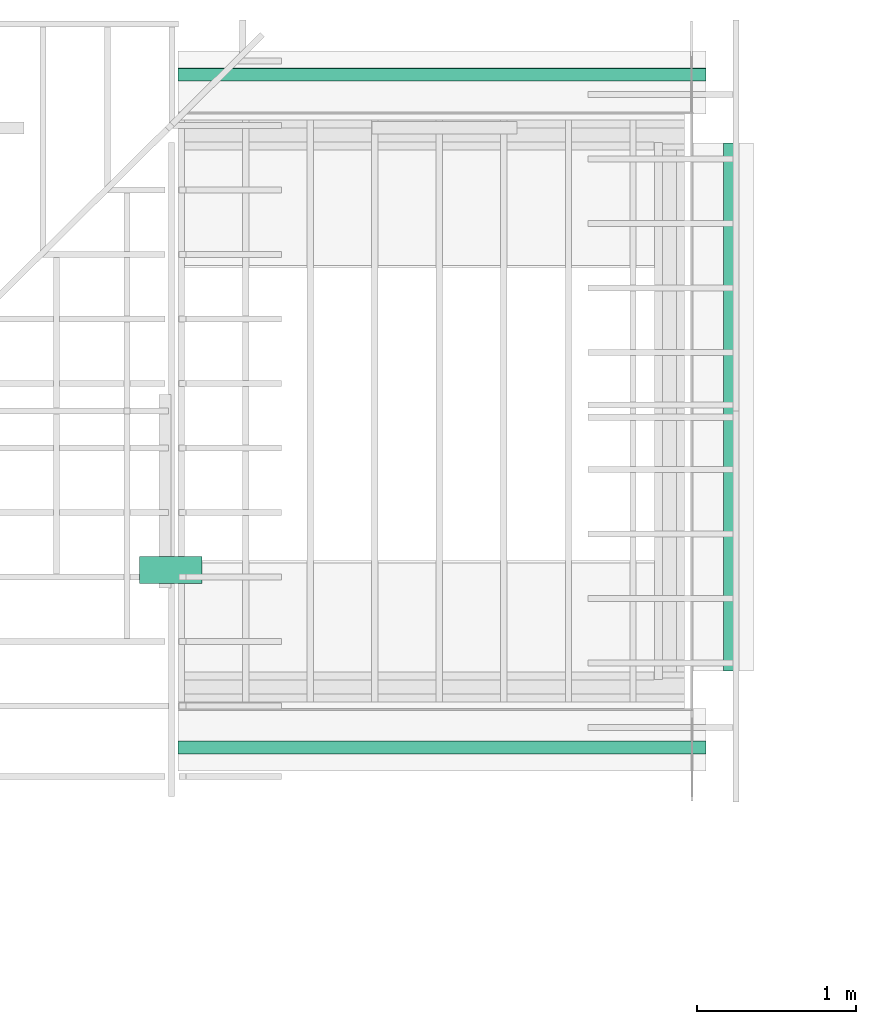
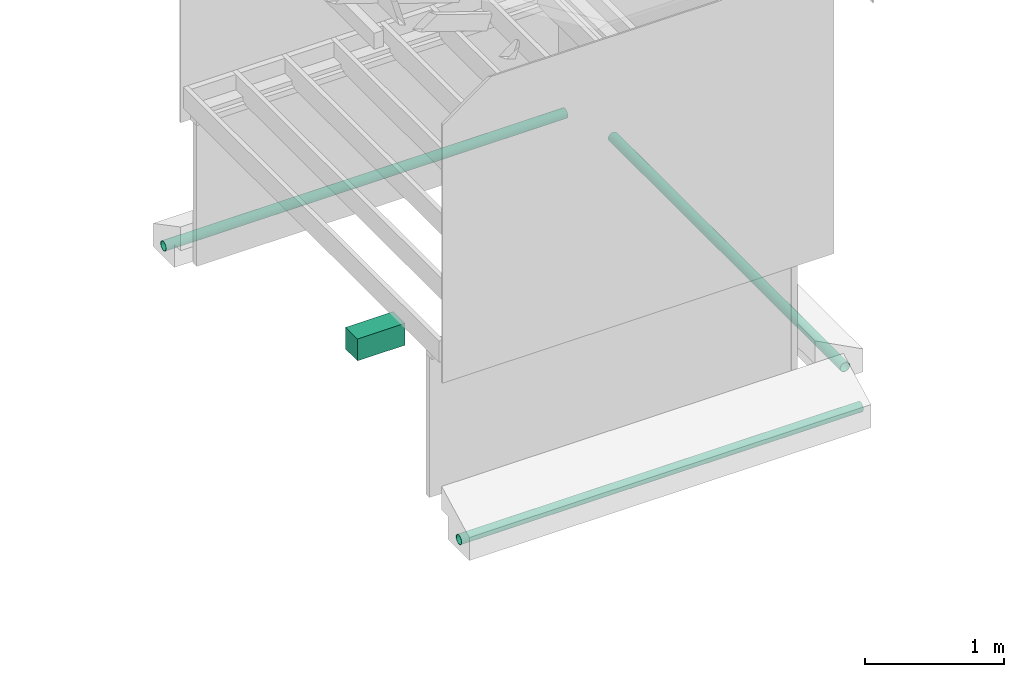
# Not in any storey, part 8 of 8: 3 pipe segments, 1 duct segment.
"""IFC4 model written with IfcOpenShell, lengths in feet."""

from ifc_helpers import new_model, entity, si_unit, converted_unit, frame, origin_with_axes, origin_2d_with_axis, place, context, subcontext, project, polygons, material, element, save


model = new_model("IFC4")

# Units and contexts
model_context = context("Model", 3, precision=1e-05, world=origin_with_axes())
plan_context = context("Plan", 2, precision=1e-05, world=origin_2d_with_axis())
context_of_model_1 = context(None, 3, precision=1e-05, world=origin_with_axes())
context_of_model_2 = context(None, 3, precision=1e-05, world=origin_with_axes())
body_context = subcontext(model_context, "Body", "Model", "MODEL_VIEW")
ifc_project = project(units=[converted_unit("PLANEANGLEUNIT", "degree", entity("IfcReal", 0.0174532925199433), si_unit("PLANEANGLEUNIT", "RADIAN"), dimensions=[0, 0, 0, 0, 0, 0, 0]), converted_unit("AREAUNIT", "square foot", entity("IfcReal", 0.09290304), si_unit("AREAUNIT", "SQUARE_METRE"), dimensions=[2, 0, 0, 0, 0, 0, 0]), converted_unit("LENGTHUNIT", "foot", entity("IfcReal", 0.3048), si_unit("LENGTHUNIT", "METRE"), dimensions=[1, 0, 0, 0, 0, 0, 0]), converted_unit("VOLUMEUNIT", "cubic foot", entity("IfcReal", 0.0283168467116885), si_unit("VOLUMEUNIT", "CUBIC_METRE"), dimensions=[3, 0, 0, 0, 0, 0, 0])], contexts=[model_context, plan_context, context_of_model_1, context_of_model_2])

# Pipe segments
ifc_material_1 = material(Name="PERFORATED DRAIN PIPE AROUND PERIMETER", Category="poche")
pipe_segment_1_placement = place(None, frame((-0.00771966193291772, 9.93598712085113, -5.18938687842662), z_axis=(0.999999999999997, 0.0, 7.54979012640431e-08), x_axis=(7.54979012640431e-08, 0.0, -0.999999999999997)))
element("IfcPipeSegment", 1, at=pipe_segment_1_placement, material=ifc_material_1, Name="Circle", PredefinedType="GUTTER", context=body_context, shape_type="Tessellation", body=[
    polygons([(0.0, 0.134125292301178, 0.0), (-0.0261665470898151, 0.13154810667038, 0.0), (-0.0513275265693665, 0.123915612697601, 0.0), (-0.0745160207152367, 0.111521109938622, 0.0), (-0.094840906560421, 0.094840906560421, 0.0), (-0.111521109938622, 0.0745160207152367, 0.0), (-0.123915612697601, 0.0513275265693665, 0.0), (-0.13154810667038, 0.0261665470898151, 0.0), (-0.134125292301178, 0.0, 0.0), (-0.13154810667038, -0.0261665470898151, 0.0), (-0.123915612697601, -0.0513275265693665, 0.0), (-0.111521109938622, -0.0745160207152367, 0.0), (-0.094840906560421, -0.094840906560421, 0.0), (-0.0745160207152367, -0.111521109938622, 0.0), (-0.0513275265693665, -0.123915612697601, 0.0), (-0.0261665470898151, -0.13154810667038, 0.0), (0.0, -0.134125292301178, 0.0), (0.0261665470898151, -0.13154810667038, 0.0), (0.0513275265693665, -0.123915612697601, 0.0), (0.0745160207152367, -0.111521109938622, 0.0), (0.094840906560421, -0.094840906560421, 0.0), (0.111521109938622, -0.0745160207152367, 0.0), (0.123915612697601, -0.0513275265693665, 0.0), (0.13154810667038, -0.0261665470898151, 0.0), (0.134125292301178, 0.0, 0.0), (0.13154810667038, 0.0261665470898151, 0.0), (0.123915612697601, 0.0513275265693665, 0.0), (0.111521109938622, 0.0745160207152367, 0.0), (0.094840906560421, 0.094840906560421, 0.0), (0.0745160207152367, 0.111521109938622, 0.0), (0.0513275265693665, 0.123915612697601, 0.0), (0.0261665470898151, 0.13154810667038, 0.0), (-8.2394694800314e-07, 0.134125292301178, -10.9135084152222), (-0.0261673722416162, 0.13154810667038, -10.9135084152222), (-0.0513283535838127, 0.123915612697601, -10.9135084152222), (-0.0745168477296829, 0.111521109938622, -10.9135084152222), (-0.0948417335748672, 0.094840906560421, -10.9135084152222), (-0.111521929502487, 0.0745160207152367, -10.9135084152222), (-0.123916439712048, 0.0513275265693665, -10.9135084152222), (-0.131548941135406, 0.0261665470898151, -10.9135084152222), (-0.134126126766205, 0.0, -10.9135084152222), (-0.131548941135406, -0.0261665470898151, -10.9135084152222), (-0.123916439712048, -0.0513275265693665, -10.9135084152222), (-0.111521929502487, -0.0745160207152367, -10.9135084152222), (-0.0948417335748672, -0.094840906560421, -10.9135084152222), (-0.0745168477296829, -0.111521109938622, -10.9135084152222), (-0.0513283535838127, -0.123915612697601, -10.9135084152222), (-0.0261673722416162, -0.13154810667038, -10.9135084152222), (-8.2394694800314e-07, -0.134125292301178, -10.9135084152222), (0.026165721938014, -0.13154810667038, -10.9135084152222), (0.0513267107307911, -0.123915612697601, -10.9135084152222), (0.0745151937007904, -0.111521109938622, -10.9135084152222), (0.0948400795459747, -0.094840906560421, -10.9135084152222), (0.111520282924175, -0.0745160207152367, -10.9135084152222), (0.123914793133736, -0.0513275265693665, -10.9135084152222), (0.131547287106514, -0.0261665470898151, -10.9135084152222), (0.134124472737312, 0.0, -10.9135084152222), (0.131547287106514, 0.0261665470898151, -10.9135084152222), (0.123914793133736, 0.0513275265693665, -10.9135084152222), (0.111520282924175, 0.0745160207152367, -10.9135084152222), (0.0948400795459747, 0.094840906560421, -10.9135084152222), (0.0745151937007904, 0.111521109938622, -10.9135084152222), (0.0513267107307911, 0.123915612697601, -10.9135084152222), (0.026165721938014, 0.13154810667038, -10.9135084152222), (-1.33095326426691e-10, 0.12481689453125, 5.28873310195172e-18), (-0.024350568652153, 0.122418567538261, -1.3785364516572e-10), (-0.0477653592824936, 0.115315772593021, -2.65495875284572e-10), (-0.0693445578217506, 0.103781454265118, -3.85479564934954e-10), (-0.0882588773965836, 0.0882588773965836, -4.95251839538469e-10), (-0.103781454265118, 0.0693445578217506, -5.84601422826125e-10), (-0.115315765142441, 0.0477653630077839, -6.52251919142088e-10), (-0.122418567538261, 0.024350568652153, -6.95251356486182e-10), (-0.12481689453125, 0.0, -7.08893166390112e-10), (-0.122418567538261, -0.024350568652153, -6.95251356486182e-10), (-0.115315765142441, -0.0477653630077839, -6.52251919142088e-10), (-0.103781454265118, -0.0693445578217506, -5.84601422826125e-10), (-0.0882588773965836, -0.0882588773965836, -4.95251839538469e-10), (-0.0693445578217506, -0.103781454265118, -3.85479564934954e-10), (-0.0477653592824936, -0.115315772593021, -2.65495875284572e-10), (-0.024350568652153, -0.122418567538261, -1.3785364516572e-10), (-1.33095326426691e-10, -0.12481689453125, 5.28873310195172e-18), (0.024350568652153, -0.122418567538261, 1.32747937642286e-10), (0.0477653592824936, -0.115315772593021, 2.60390237150077e-10), (0.0693445578217506, -0.103781454265118, 3.8803252278008e-10), (0.0882588773965836, -0.0882588773965836, 5.00357588695266e-10), (0.103781469166279, -0.0693445578217506, 5.87154214137797e-10), (0.115315772593021, -0.0477653592824936, 6.47465248082568e-10), (0.122418567538261, -0.0243505705147982, 6.85239420761263e-10), (0.12481689453125, 0.0, 6.98442415014711e-10), (0.122418567538261, 0.0243505705147982, 6.85239420761263e-10), (0.115315772593021, 0.0477653592824936, 6.47465248082568e-10), (0.103781469166279, 0.0693445578217506, 5.87154214137797e-10), (0.0882588773965836, 0.0882588773965836, 5.00357588695266e-10), (0.0693445578217506, 0.103781454265118, 3.8803252278008e-10), (0.0477653592824936, 0.115315772593021, 2.60390237150077e-10), (0.024350568652153, 0.122418567538261, 1.32747937642286e-10), (-8.23991342713271e-07, 0.12481689453125, -10.9135084152222), (-0.0243513938039541, 0.122418567538261, -10.9135084152222), (-0.0477661862969398, 0.115315772593021, -10.9135084152222), (-0.0693453848361969, 0.103781454265118, -10.9135084152222), (-0.0882596969604492, 0.0882588773965836, -10.9135084152222), (-0.103782288730145, 0.0693445578217506, -10.9135084152222), (-0.115316592156887, 0.0477653630077839, -10.9135084152222), (-0.122419394552708, 0.024350568652153, -10.9135084152222), (-0.124817721545696, 0.0, -10.9135084152222), (-0.122419394552708, -0.024350568652153, -10.9135084152222), (-0.115316592156887, -0.0477653630077839, -10.9135084152222), (-0.103782288730145, -0.0693445578217506, -10.9135084152222), (-0.0882596969604492, -0.0882588773965836, -10.9135084152222), (-0.0693453848361969, -0.103781454265118, -10.9135084152222), (-0.0477661862969398, -0.115315772593021, -10.9135084152222), (-0.0243513938039541, -0.122418567538261, -10.9135084152222), (-8.23991342713271e-07, -0.12481689453125, -10.9135084152222), (0.0243497435003519, -0.122418567538261, -10.9135084152222), (0.0477645397186279, -0.115315772593021, -10.9135084152222), (0.0693437233567238, -0.103781454265118, -10.9135084152222), (0.0882580503821373, -0.0882588773965836, -10.9135084152222), (0.103780634701252, -0.0693445578217506, -10.9135084152222), (0.115314953029156, -0.0477653592824936, -10.9135084152222), (0.122417747974396, -0.0243505705147982, -10.9135084152222), (0.124816074967384, 0.0, -10.9135084152222), (0.122417747974396, 0.0243505705147982, -10.9135084152222), (0.115314953029156, 0.0477653592824936, -10.9135084152222), (0.103780634701252, 0.0693445578217506, -10.9135084152222), (0.0882580503821373, 0.0882588773965836, -10.9135084152222), (0.0693437233567238, 0.103781454265118, -10.9135084152222), (0.0477645397186279, 0.115315772593021, -10.9135084152222), (0.0243497435003519, 0.122418567538261, -10.9135084152222)], [[[26, 25, 57, 58]], [[13, 12, 44, 45]], [[27, 26, 58, 59]], [[14, 13, 45, 46]], [[28, 27, 59, 60]], [[15, 14, 46, 47]], [[2, 1, 33, 34]], [[29, 28, 60, 61]], [[16, 15, 47, 48]], [[3, 2, 34, 35]], [[30, 29, 61, 62]], [[17, 16, 48, 49]], [[4, 3, 35, 36]], [[31, 30, 62, 63]], [[18, 17, 49, 50]], [[5, 4, 36, 37]], [[32, 31, 63, 64]], [[19, 18, 50, 51]], [[6, 5, 37, 38]], [[1, 32, 64, 33]], [[20, 19, 51, 52]], [[7, 6, 38, 39]], [[21, 20, 52, 53]], [[8, 7, 39, 40]], [[22, 21, 53, 54]], [[9, 8, 40, 41]], [[23, 22, 54, 55]], [[10, 9, 41, 42]], [[24, 23, 55, 56]], [[11, 10, 42, 43]], [[25, 24, 56, 57]], [[12, 11, 43, 44]], [[90, 122, 121, 89]], [[77, 109, 108, 76]], [[91, 123, 122, 90]], [[78, 110, 109, 77]], [[92, 124, 123, 91]], [[79, 111, 110, 78]], [[66, 98, 97, 65]], [[93, 125, 124, 92]], [[80, 112, 111, 79]], [[67, 99, 98, 66]], [[94, 126, 125, 93]], [[81, 113, 112, 80]], [[68, 100, 99, 67]], [[95, 127, 126, 94]], [[82, 114, 113, 81]], [[69, 101, 100, 68]], [[96, 128, 127, 95]], [[83, 115, 114, 82]], [[70, 102, 101, 69]], [[65, 97, 128, 96]], [[84, 116, 115, 83]], [[71, 103, 102, 70]], [[85, 117, 116, 84]], [[72, 104, 103, 71]], [[86, 118, 117, 85]], [[73, 105, 104, 72]], [[87, 119, 118, 86]], [[74, 106, 105, 73]], [[88, 120, 119, 87]], [[75, 107, 106, 74]], [[89, 121, 120, 88]], [[76, 108, 107, 75]], [[1, 2, 66, 65]], [[2, 3, 67, 66]], [[3, 4, 68, 67]], [[4, 5, 69, 68]], [[5, 6, 70, 69]], [[6, 7, 71, 70]], [[7, 8, 72, 71]], [[8, 9, 73, 72]], [[9, 10, 74, 73]], [[10, 11, 75, 74]], [[11, 12, 76, 75]], [[12, 13, 77, 76]], [[13, 14, 78, 77]], [[14, 15, 79, 78]], [[15, 16, 80, 79]], [[16, 17, 81, 80]], [[17, 18, 82, 81]], [[18, 19, 83, 82]], [[19, 20, 84, 83]], [[20, 21, 85, 84]], [[21, 22, 86, 85]], [[22, 23, 87, 86]], [[23, 24, 88, 87]], [[24, 25, 89, 88]], [[25, 26, 90, 89]], [[26, 27, 91, 90]], [[27, 28, 92, 91]], [[28, 29, 93, 92]], [[29, 30, 94, 93]], [[30, 31, 95, 94]], [[31, 32, 96, 95]], [[32, 1, 65, 96]], [[34, 33, 97, 98]], [[35, 34, 98, 99]], [[36, 35, 99, 100]], [[37, 36, 100, 101]], [[38, 37, 101, 102]], [[39, 38, 102, 103]], [[40, 39, 103, 104]], [[41, 40, 104, 105]], [[42, 41, 105, 106]], [[43, 42, 106, 107]], [[44, 43, 107, 108]], [[45, 44, 108, 109]], [[46, 45, 109, 110]], [[47, 46, 110, 111]], [[48, 47, 111, 112]], [[49, 48, 112, 113]], [[50, 49, 113, 114]], [[51, 50, 114, 115]], [[52, 51, 115, 116]], [[53, 52, 116, 117]], [[54, 53, 117, 118]], [[55, 54, 118, 119]], [[56, 55, 119, 120]], [[57, 56, 120, 121]], [[58, 57, 121, 122]], [[59, 58, 122, 123]], [[60, 59, 123, 124]], [[61, 60, 124, 125]], [[62, 61, 125, 126]], [[63, 62, 126, 127]], [[64, 63, 127, 128]], [[33, 64, 128, 97]]], closed=True),
])
pipe_segment_2_placement = place(None, frame((-0.00771966193291772, -3.9690318382944, -5.18938687842662), z_axis=(0.999999999999997, 0.0, 7.54979012640431e-08), x_axis=(7.54979012640431e-08, 0.0, -0.999999999999997)))
element("IfcPipeSegment", 2, at=pipe_segment_2_placement, material=ifc_material_1, Name="Circle", PredefinedType="GUTTER", context=body_context, shape_type="Tessellation", body=[
    polygons([(0.0, -0.134125292301178, 0.0), (-0.0261665470898151, -0.13154810667038, 0.0), (-0.0513275265693665, -0.123915612697601, 0.0), (-0.0745160207152367, -0.111521109938622, 0.0), (-0.094840906560421, -0.094840906560421, 0.0), (-0.111521109938622, -0.0745160207152367, 0.0), (-0.123915612697601, -0.0513275265693665, 0.0), (-0.13154810667038, -0.0261665470898151, 0.0), (-0.134125292301178, 0.0, 0.0), (-0.13154810667038, 0.0261665470898151, 0.0), (-0.123915612697601, 0.0513275265693665, 0.0), (-0.111521109938622, 0.0745160207152367, 0.0), (-0.094840906560421, 0.094840906560421, 0.0), (-0.0745160207152367, 0.111521109938622, 0.0), (-0.0513275265693665, 0.123915612697601, 0.0), (-0.0261665470898151, 0.13154810667038, 0.0), (0.0, 0.134125292301178, 0.0), (0.0261665470898151, 0.13154810667038, 0.0), (0.0513275265693665, 0.123915612697601, 0.0), (0.0745160207152367, 0.111521109938622, 0.0), (0.094840906560421, 0.094840906560421, 0.0), (0.111521109938622, 0.0745160207152367, 0.0), (0.123915612697601, 0.0513275265693665, 0.0), (0.13154810667038, 0.0261665470898151, 0.0), (0.134125292301178, 0.0, 0.0), (0.13154810667038, -0.0261665470898151, 0.0), (0.123915612697601, -0.0513275265693665, 0.0), (0.111521109938622, -0.0745160207152367, 0.0), (0.094840906560421, -0.094840906560421, 0.0), (0.0745160207152367, -0.111521109938622, 0.0), (0.0513275265693665, -0.123915612697601, 0.0), (0.0261665470898151, -0.13154810667038, 0.0), (-8.2394694800314e-07, -0.134125292301178, -10.9135084152222), (-0.0261673722416162, -0.13154810667038, -10.9135084152222), (-0.0513283535838127, -0.123915612697601, -10.9135084152222), (-0.0745168477296829, -0.111521109938622, -10.9135084152222), (-0.0948417335748672, -0.094840906560421, -10.9135084152222), (-0.111521929502487, -0.0745160207152367, -10.9135084152222), (-0.123916439712048, -0.0513275265693665, -10.9135084152222), (-0.131548941135406, -0.0261665470898151, -10.9135084152222), (-0.134126126766205, 0.0, -10.9135084152222), (-0.131548941135406, 0.0261665470898151, -10.9135084152222), (-0.123916439712048, 0.0513275265693665, -10.9135084152222), (-0.111521929502487, 0.0745160207152367, -10.9135084152222), (-0.0948417335748672, 0.094840906560421, -10.9135084152222), (-0.0745168477296829, 0.111521109938622, -10.9135084152222), (-0.0513283535838127, 0.123915612697601, -10.9135084152222), (-0.0261673722416162, 0.13154810667038, -10.9135084152222), (-8.2394694800314e-07, 0.134125292301178, -10.9135084152222), (0.026165721938014, 0.13154810667038, -10.9135084152222), (0.0513267107307911, 0.123915612697601, -10.9135084152222), (0.0745151937007904, 0.111521109938622, -10.9135084152222), (0.0948400795459747, 0.094840906560421, -10.9135084152222), (0.111520282924175, 0.0745160207152367, -10.9135084152222), (0.123914793133736, 0.0513275265693665, -10.9135084152222), (0.131547287106514, 0.0261665470898151, -10.9135084152222), (0.134124472737312, 0.0, -10.9135084152222), (0.131547287106514, -0.0261665470898151, -10.9135084152222), (0.123914793133736, -0.0513275265693665, -10.9135084152222), (0.111520282924175, -0.0745160207152367, -10.9135084152222), (0.0948400795459747, -0.094840906560421, -10.9135084152222), (0.0745151937007904, -0.111521109938622, -10.9135084152222), (0.0513267107307911, -0.123915612697601, -10.9135084152222), (0.026165721938014, -0.13154810667038, -10.9135084152222), (-1.33095326426691e-10, -0.12481689453125, 5.28873310195172e-18), (-0.024350568652153, -0.122418567538261, -1.3785364516572e-10), (-0.0477653592824936, -0.115315772593021, -2.65495875284572e-10), (-0.0693445578217506, -0.103781454265118, -3.85479564934954e-10), (-0.0882588773965836, -0.0882588773965836, -4.95251839538469e-10), (-0.103781454265118, -0.0693445578217506, -5.84601422826125e-10), (-0.115315765142441, -0.0477653630077839, -6.52251919142088e-10), (-0.122418567538261, -0.024350568652153, -6.95251356486182e-10), (-0.12481689453125, 0.0, -7.08893166390112e-10), (-0.122418567538261, 0.024350568652153, -6.95251356486182e-10), (-0.115315765142441, 0.0477653630077839, -6.52251919142088e-10), (-0.103781454265118, 0.0693445578217506, -5.84601422826125e-10), (-0.0882588773965836, 0.0882588773965836, -4.95251839538469e-10), (-0.0693445578217506, 0.103781454265118, -3.85479564934954e-10), (-0.0477653592824936, 0.115315772593021, -2.65495875284572e-10), (-0.024350568652153, 0.122418567538261, -1.3785364516572e-10), (-1.33095326426691e-10, 0.12481689453125, 5.28873310195172e-18), (0.024350568652153, 0.122418567538261, 1.32747937642286e-10), (0.0477653592824936, 0.115315772593021, 2.60390237150077e-10), (0.0693445578217506, 0.103781454265118, 3.8803252278008e-10), (0.0882588773965836, 0.0882588773965836, 5.00357588695266e-10), (0.103781469166279, 0.0693445578217506, 5.87154214137797e-10), (0.115315772593021, 0.0477653592824936, 6.47465248082568e-10), (0.122418567538261, 0.0243505705147982, 6.85239420761263e-10), (0.12481689453125, 0.0, 6.98442415014711e-10), (0.122418567538261, -0.0243505705147982, 6.85239420761263e-10), (0.115315772593021, -0.0477653592824936, 6.47465248082568e-10), (0.103781469166279, -0.0693445578217506, 5.87154214137797e-10), (0.0882588773965836, -0.0882588773965836, 5.00357588695266e-10), (0.0693445578217506, -0.103781454265118, 3.8803252278008e-10), (0.0477653592824936, -0.115315772593021, 2.60390237150077e-10), (0.024350568652153, -0.122418567538261, 1.32747937642286e-10), (-8.23991342713271e-07, -0.12481689453125, -10.9135084152222), (-0.0243513938039541, -0.122418567538261, -10.9135084152222), (-0.0477661862969398, -0.115315772593021, -10.9135084152222), (-0.0693453848361969, -0.103781454265118, -10.9135084152222), (-0.0882596969604492, -0.0882588773965836, -10.9135084152222), (-0.103782288730145, -0.0693445578217506, -10.9135084152222), (-0.115316592156887, -0.0477653630077839, -10.9135084152222), (-0.122419394552708, -0.024350568652153, -10.9135084152222), (-0.124817721545696, 0.0, -10.9135084152222), (-0.122419394552708, 0.024350568652153, -10.9135084152222), (-0.115316592156887, 0.0477653630077839, -10.9135084152222), (-0.103782288730145, 0.0693445578217506, -10.9135084152222), (-0.0882596969604492, 0.0882588773965836, -10.9135084152222), (-0.0693453848361969, 0.103781454265118, -10.9135084152222), (-0.0477661862969398, 0.115315772593021, -10.9135084152222), (-0.0243513938039541, 0.122418567538261, -10.9135084152222), (-8.23991342713271e-07, 0.12481689453125, -10.9135084152222), (0.0243497435003519, 0.122418567538261, -10.9135084152222), (0.0477645397186279, 0.115315772593021, -10.9135084152222), (0.0693437233567238, 0.103781454265118, -10.9135084152222), (0.0882580503821373, 0.0882588773965836, -10.9135084152222), (0.103780634701252, 0.0693445578217506, -10.9135084152222), (0.115314953029156, 0.0477653592824936, -10.9135084152222), (0.122417747974396, 0.0243505705147982, -10.9135084152222), (0.124816074967384, 0.0, -10.9135084152222), (0.122417747974396, -0.0243505705147982, -10.9135084152222), (0.115314953029156, -0.0477653592824936, -10.9135084152222), (0.103780634701252, -0.0693445578217506, -10.9135084152222), (0.0882580503821373, -0.0882588773965836, -10.9135084152222), (0.0693437233567238, -0.103781454265118, -10.9135084152222), (0.0477645397186279, -0.115315772593021, -10.9135084152222), (0.0243497435003519, -0.122418567538261, -10.9135084152222)], [[[26, 25, 57, 58]], [[13, 12, 44, 45]], [[27, 26, 58, 59]], [[14, 13, 45, 46]], [[28, 27, 59, 60]], [[15, 14, 46, 47]], [[2, 1, 33, 34]], [[29, 28, 60, 61]], [[16, 15, 47, 48]], [[3, 2, 34, 35]], [[30, 29, 61, 62]], [[17, 16, 48, 49]], [[4, 3, 35, 36]], [[31, 30, 62, 63]], [[18, 17, 49, 50]], [[5, 4, 36, 37]], [[32, 31, 63, 64]], [[19, 18, 50, 51]], [[6, 5, 37, 38]], [[1, 32, 64, 33]], [[20, 19, 51, 52]], [[7, 6, 38, 39]], [[21, 20, 52, 53]], [[8, 7, 39, 40]], [[22, 21, 53, 54]], [[9, 8, 40, 41]], [[23, 22, 54, 55]], [[10, 9, 41, 42]], [[24, 23, 55, 56]], [[11, 10, 42, 43]], [[25, 24, 56, 57]], [[12, 11, 43, 44]], [[90, 122, 121, 89]], [[77, 109, 108, 76]], [[91, 123, 122, 90]], [[78, 110, 109, 77]], [[92, 124, 123, 91]], [[79, 111, 110, 78]], [[66, 98, 97, 65]], [[93, 125, 124, 92]], [[80, 112, 111, 79]], [[67, 99, 98, 66]], [[94, 126, 125, 93]], [[81, 113, 112, 80]], [[68, 100, 99, 67]], [[95, 127, 126, 94]], [[82, 114, 113, 81]], [[69, 101, 100, 68]], [[96, 128, 127, 95]], [[83, 115, 114, 82]], [[70, 102, 101, 69]], [[65, 97, 128, 96]], [[84, 116, 115, 83]], [[71, 103, 102, 70]], [[85, 117, 116, 84]], [[72, 104, 103, 71]], [[86, 118, 117, 85]], [[73, 105, 104, 72]], [[87, 119, 118, 86]], [[74, 106, 105, 73]], [[88, 120, 119, 87]], [[75, 107, 106, 74]], [[89, 121, 120, 88]], [[76, 108, 107, 75]], [[1, 2, 66, 65]], [[2, 3, 67, 66]], [[3, 4, 68, 67]], [[4, 5, 69, 68]], [[5, 6, 70, 69]], [[6, 7, 71, 70]], [[7, 8, 72, 71]], [[8, 9, 73, 72]], [[9, 10, 74, 73]], [[10, 11, 75, 74]], [[11, 12, 76, 75]], [[12, 13, 77, 76]], [[13, 14, 78, 77]], [[14, 15, 79, 78]], [[15, 16, 80, 79]], [[16, 17, 81, 80]], [[17, 18, 82, 81]], [[18, 19, 83, 82]], [[19, 20, 84, 83]], [[20, 21, 85, 84]], [[21, 22, 86, 85]], [[22, 23, 87, 86]], [[23, 24, 88, 87]], [[24, 25, 89, 88]], [[25, 26, 90, 89]], [[26, 27, 91, 90]], [[27, 28, 92, 91]], [[28, 29, 93, 92]], [[29, 30, 94, 93]], [[30, 31, 95, 94]], [[31, 32, 96, 95]], [[32, 1, 65, 96]], [[34, 33, 97, 98]], [[35, 34, 98, 99]], [[36, 35, 99, 100]], [[37, 36, 100, 101]], [[38, 37, 101, 102]], [[39, 38, 102, 103]], [[40, 39, 103, 104]], [[41, 40, 104, 105]], [[42, 41, 105, 106]], [[43, 42, 106, 107]], [[44, 43, 107, 108]], [[45, 44, 108, 109]], [[46, 45, 109, 110]], [[47, 46, 110, 111]], [[48, 47, 111, 112]], [[49, 48, 112, 113]], [[50, 49, 113, 114]], [[51, 50, 114, 115]], [[52, 51, 115, 116]], [[53, 52, 116, 117]], [[54, 53, 117, 118]], [[55, 54, 118, 119]], [[56, 55, 119, 120]], [[57, 56, 120, 121]], [[58, 57, 121, 122]], [[59, 58, 122, 123]], [[60, 59, 123, 124]], [[61, 60, 124, 125]], [[62, 61, 125, 126]], [[63, 62, 126, 127]], [[64, 63, 127, 128]], [[33, 64, 128, 97]]], closed=True),
])

# Duct segment
ifc_material_2 = material(Name="DUCT - SIZE TBD", Category="poche")
duct_segment_placement = place(None, frame((-11.5046053733726, 0.209779603274788, -1.61171037693975), z_axis=(0.0, 0.0, 1.0), x_axis=(1.0, 0.0, 0.0)))
element("IfcDuctSegment", 3, at=duct_segment_placement, material=ifc_material_2, Name="Duct", PredefinedType="NOTDEFINED", context=body_context, shape_type="Tessellation", body=[
    polygons([(-0.218726173043251, -0.795728385448456, -0.218726173043251), (-0.218726173043251, -0.795728385448456, 0.409292697906494), (-0.218726173043251, -0.23759263753891, -0.218726173043251), (-0.218726173043251, -0.23759263753891, 0.409292697906494), (1.07396411895752, -0.795728385448456, -0.218726173043251), (1.07396411895752, -0.795728385448456, 0.409292697906494), (1.07396411895752, -0.23759263753891, -0.218726173043251), (1.07396411895752, -0.23759263753891, 0.409292697906494)], [[[1, 2, 4, 3]], [[3, 4, 8, 7]], [[7, 8, 6, 5]], [[5, 6, 2, 1]], [[3, 7, 5, 1]], [[8, 4, 2, 6]]], closed=True),
])

# Pipe segment
pipe_segment_3_placement = place(None, frame((0.481932690450213, 8.52612607435291, -5.18938687842662), z_axis=(-4.37113882867379e-08, 0.999999999999999, -3.30011807777566e-15), x_axis=(7.54979012640431e-08, 0.0, -0.999999999999997)))
element("IfcPipeSegment", 4, at=pipe_segment_3_placement, material=ifc_material_1, Name="Circle", PredefinedType="GUTTER", context=body_context, shape_type="Tessellation", body=[
    polygons([(0.0, -0.134125292301178, 0.0), (-0.0261665470898151, -0.13154810667038, 0.0), (-0.0513275265693665, -0.123915612697601, 0.0), (-0.0745160207152367, -0.111521109938622, 0.0), (-0.094840906560421, -0.094840906560421, 0.0), (-0.111521109938622, -0.0745160207152367, 0.0), (-0.123915612697601, -0.0513275265693665, 0.0), (-0.13154810667038, -0.0261665470898151, 0.0), (-0.134125292301178, 0.0, 0.0), (-0.13154810667038, 0.0261665470898151, 0.0), (-0.123915612697601, 0.0513275265693665, 0.0), (-0.111521109938622, 0.0745160207152367, 0.0), (-0.094840906560421, 0.094840906560421, 0.0), (-0.0745160207152367, 0.111521109938622, 0.0), (-0.0513275265693665, 0.123915612697601, 0.0), (-0.0261665470898151, 0.13154810667038, 0.0), (0.0, 0.134125292301178, 0.0), (0.0261665470898151, 0.13154810667038, 0.0), (0.0513275265693665, 0.123915612697601, 0.0), (0.0745160207152367, 0.111521109938622, 0.0), (0.094840906560421, 0.094840906560421, 0.0), (0.111521109938622, 0.0745160207152367, 0.0), (0.123915612697601, 0.0513275265693665, 0.0), (0.13154810667038, 0.0261665470898151, 0.0), (0.134125292301178, 0.0, 0.0), (0.13154810667038, -0.0261665470898151, 0.0), (0.123915612697601, -0.0513275265693665, 0.0), (0.111521109938622, -0.0745160207152367, 0.0), (0.094840906560421, -0.094840906560421, 0.0), (0.0745160207152367, -0.111521109938622, 0.0), (0.0513275265693665, -0.123915612697601, 0.0), (0.0261665470898151, -0.13154810667038, 0.0), (-8.2394694800314e-07, -0.134125292301178, -10.9135084152222), (-0.0261673722416162, -0.13154810667038, -10.9135084152222), (-0.0513283535838127, -0.123915612697601, -10.9135084152222), (-0.0745168477296829, -0.111521109938622, -10.9135084152222), (-0.0948417335748672, -0.094840906560421, -10.9135084152222), (-0.111521929502487, -0.0745160207152367, -10.9135084152222), (-0.123916439712048, -0.0513275265693665, -10.9135084152222), (-0.131548941135406, -0.0261665470898151, -10.9135084152222), (-0.134126126766205, 0.0, -10.9135084152222), (-0.131548941135406, 0.0261665470898151, -10.9135084152222), (-0.123916439712048, 0.0513275265693665, -10.9135084152222), (-0.111521929502487, 0.0745160207152367, -10.9135084152222), (-0.0948417335748672, 0.094840906560421, -10.9135084152222), (-0.0745168477296829, 0.111521109938622, -10.9135084152222), (-0.0513283535838127, 0.123915612697601, -10.9135084152222), (-0.0261673722416162, 0.13154810667038, -10.9135084152222), (-8.2394694800314e-07, 0.134125292301178, -10.9135084152222), (0.026165721938014, 0.13154810667038, -10.9135084152222), (0.0513267107307911, 0.123915612697601, -10.9135084152222), (0.0745151937007904, 0.111521109938622, -10.9135084152222), (0.0948400795459747, 0.094840906560421, -10.9135084152222), (0.111520282924175, 0.0745160207152367, -10.9135084152222), (0.123914793133736, 0.0513275265693665, -10.9135084152222), (0.131547287106514, 0.0261665470898151, -10.9135084152222), (0.134124472737312, 0.0, -10.9135084152222), (0.131547287106514, -0.0261665470898151, -10.9135084152222), (0.123914793133736, -0.0513275265693665, -10.9135084152222), (0.111520282924175, -0.0745160207152367, -10.9135084152222), (0.0948400795459747, -0.094840906560421, -10.9135084152222), (0.0745151937007904, -0.111521109938622, -10.9135084152222), (0.0513267107307911, -0.123915612697601, -10.9135084152222), (0.026165721938014, -0.13154810667038, -10.9135084152222), (-1.33095326426691e-10, -0.12481689453125, 5.28873310195172e-18), (-0.024350568652153, -0.122418567538261, -1.3785364516572e-10), (-0.0477653592824936, -0.115315772593021, -2.65495875284572e-10), (-0.0693445578217506, -0.103781454265118, -3.85479564934954e-10), (-0.0882588773965836, -0.0882588773965836, -4.95251839538469e-10), (-0.103781454265118, -0.0693445578217506, -5.84601422826125e-10), (-0.115315765142441, -0.0477653630077839, -6.52251919142088e-10), (-0.122418567538261, -0.024350568652153, -6.95251356486182e-10), (-0.12481689453125, 0.0, -7.08893166390112e-10), (-0.122418567538261, 0.024350568652153, -6.95251356486182e-10), (-0.115315765142441, 0.0477653630077839, -6.52251919142088e-10), (-0.103781454265118, 0.0693445578217506, -5.84601422826125e-10), (-0.0882588773965836, 0.0882588773965836, -4.95251839538469e-10), (-0.0693445578217506, 0.103781454265118, -3.85479564934954e-10), (-0.0477653592824936, 0.115315772593021, -2.65495875284572e-10), (-0.024350568652153, 0.122418567538261, -1.3785364516572e-10), (-1.33095326426691e-10, 0.12481689453125, 5.28873310195172e-18), (0.024350568652153, 0.122418567538261, 1.32747937642286e-10), (0.0477653592824936, 0.115315772593021, 2.60390237150077e-10), (0.0693445578217506, 0.103781454265118, 3.8803252278008e-10), (0.0882588773965836, 0.0882588773965836, 5.00357588695266e-10), (0.103781469166279, 0.0693445578217506, 5.87154214137797e-10), (0.115315772593021, 0.0477653592824936, 6.47465248082568e-10), (0.122418567538261, 0.0243505705147982, 6.85239420761263e-10), (0.12481689453125, 0.0, 6.98442415014711e-10), (0.122418567538261, -0.0243505705147982, 6.85239420761263e-10), (0.115315772593021, -0.0477653592824936, 6.47465248082568e-10), (0.103781469166279, -0.0693445578217506, 5.87154214137797e-10), (0.0882588773965836, -0.0882588773965836, 5.00357588695266e-10), (0.0693445578217506, -0.103781454265118, 3.8803252278008e-10), (0.0477653592824936, -0.115315772593021, 2.60390237150077e-10), (0.024350568652153, -0.122418567538261, 1.32747937642286e-10), (-8.23991342713271e-07, -0.12481689453125, -10.9135084152222), (-0.0243513938039541, -0.122418567538261, -10.9135084152222), (-0.0477661862969398, -0.115315772593021, -10.9135084152222), (-0.0693453848361969, -0.103781454265118, -10.9135084152222), (-0.0882596969604492, -0.0882588773965836, -10.9135084152222), (-0.103782288730145, -0.0693445578217506, -10.9135084152222), (-0.115316592156887, -0.0477653630077839, -10.9135084152222), (-0.122419394552708, -0.024350568652153, -10.9135084152222), (-0.124817721545696, 0.0, -10.9135084152222), (-0.122419394552708, 0.024350568652153, -10.9135084152222), (-0.115316592156887, 0.0477653630077839, -10.9135084152222), (-0.103782288730145, 0.0693445578217506, -10.9135084152222), (-0.0882596969604492, 0.0882588773965836, -10.9135084152222), (-0.0693453848361969, 0.103781454265118, -10.9135084152222), (-0.0477661862969398, 0.115315772593021, -10.9135084152222), (-0.0243513938039541, 0.122418567538261, -10.9135084152222), (-8.23991342713271e-07, 0.12481689453125, -10.9135084152222), (0.0243497435003519, 0.122418567538261, -10.9135084152222), (0.0477645397186279, 0.115315772593021, -10.9135084152222), (0.0693437233567238, 0.103781454265118, -10.9135084152222), (0.0882580503821373, 0.0882588773965836, -10.9135084152222), (0.103780634701252, 0.0693445578217506, -10.9135084152222), (0.115314953029156, 0.0477653592824936, -10.9135084152222), (0.122417747974396, 0.0243505705147982, -10.9135084152222), (0.124816074967384, 0.0, -10.9135084152222), (0.122417747974396, -0.0243505705147982, -10.9135084152222), (0.115314953029156, -0.0477653592824936, -10.9135084152222), (0.103780634701252, -0.0693445578217506, -10.9135084152222), (0.0882580503821373, -0.0882588773965836, -10.9135084152222), (0.0693437233567238, -0.103781454265118, -10.9135084152222), (0.0477645397186279, -0.115315772593021, -10.9135084152222), (0.0243497435003519, -0.122418567538261, -10.9135084152222)], [[[26, 25, 57, 58]], [[13, 12, 44, 45]], [[27, 26, 58, 59]], [[14, 13, 45, 46]], [[28, 27, 59, 60]], [[15, 14, 46, 47]], [[2, 1, 33, 34]], [[29, 28, 60, 61]], [[16, 15, 47, 48]], [[3, 2, 34, 35]], [[30, 29, 61, 62]], [[17, 16, 48, 49]], [[4, 3, 35, 36]], [[31, 30, 62, 63]], [[18, 17, 49, 50]], [[5, 4, 36, 37]], [[32, 31, 63, 64]], [[19, 18, 50, 51]], [[6, 5, 37, 38]], [[1, 32, 64, 33]], [[20, 19, 51, 52]], [[7, 6, 38, 39]], [[21, 20, 52, 53]], [[8, 7, 39, 40]], [[22, 21, 53, 54]], [[9, 8, 40, 41]], [[23, 22, 54, 55]], [[10, 9, 41, 42]], [[24, 23, 55, 56]], [[11, 10, 42, 43]], [[25, 24, 56, 57]], [[12, 11, 43, 44]], [[90, 122, 121, 89]], [[77, 109, 108, 76]], [[91, 123, 122, 90]], [[78, 110, 109, 77]], [[92, 124, 123, 91]], [[79, 111, 110, 78]], [[66, 98, 97, 65]], [[93, 125, 124, 92]], [[80, 112, 111, 79]], [[67, 99, 98, 66]], [[94, 126, 125, 93]], [[81, 113, 112, 80]], [[68, 100, 99, 67]], [[95, 127, 126, 94]], [[82, 114, 113, 81]], [[69, 101, 100, 68]], [[96, 128, 127, 95]], [[83, 115, 114, 82]], [[70, 102, 101, 69]], [[65, 97, 128, 96]], [[84, 116, 115, 83]], [[71, 103, 102, 70]], [[85, 117, 116, 84]], [[72, 104, 103, 71]], [[86, 118, 117, 85]], [[73, 105, 104, 72]], [[87, 119, 118, 86]], [[74, 106, 105, 73]], [[88, 120, 119, 87]], [[75, 107, 106, 74]], [[89, 121, 120, 88]], [[76, 108, 107, 75]], [[1, 2, 66, 65]], [[2, 3, 67, 66]], [[3, 4, 68, 67]], [[4, 5, 69, 68]], [[5, 6, 70, 69]], [[6, 7, 71, 70]], [[7, 8, 72, 71]], [[8, 9, 73, 72]], [[9, 10, 74, 73]], [[10, 11, 75, 74]], [[11, 12, 76, 75]], [[12, 13, 77, 76]], [[13, 14, 78, 77]], [[14, 15, 79, 78]], [[15, 16, 80, 79]], [[16, 17, 81, 80]], [[17, 18, 82, 81]], [[18, 19, 83, 82]], [[19, 20, 84, 83]], [[20, 21, 85, 84]], [[21, 22, 86, 85]], [[22, 23, 87, 86]], [[23, 24, 88, 87]], [[24, 25, 89, 88]], [[25, 26, 90, 89]], [[26, 27, 91, 90]], [[27, 28, 92, 91]], [[28, 29, 93, 92]], [[29, 30, 94, 93]], [[30, 31, 95, 94]], [[31, 32, 96, 95]], [[32, 1, 65, 96]], [[34, 33, 97, 98]], [[35, 34, 98, 99]], [[36, 35, 99, 100]], [[37, 36, 100, 101]], [[38, 37, 101, 102]], [[39, 38, 102, 103]], [[40, 39, 103, 104]], [[41, 40, 104, 105]], [[42, 41, 105, 106]], [[43, 42, 106, 107]], [[44, 43, 107, 108]], [[45, 44, 108, 109]], [[46, 45, 109, 110]], [[47, 46, 110, 111]], [[48, 47, 111, 112]], [[49, 48, 112, 113]], [[50, 49, 113, 114]], [[51, 50, 114, 115]], [[52, 51, 115, 116]], [[53, 52, 116, 117]], [[54, 53, 117, 118]], [[55, 54, 118, 119]], [[56, 55, 119, 120]], [[57, 56, 120, 121]], [[58, 57, 121, 122]], [[59, 58, 122, 123]], [[60, 59, 123, 124]], [[61, 60, 124, 125]], [[62, 61, 125, 126]], [[63, 62, 126, 127]], [[64, 63, 127, 128]], [[33, 64, 128, 97]]], closed=True),
])

save(model, "model.ifc")
